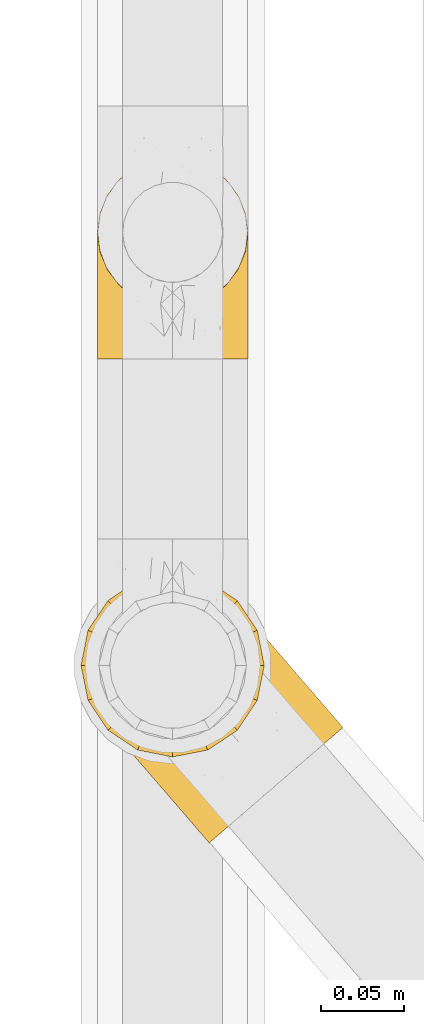
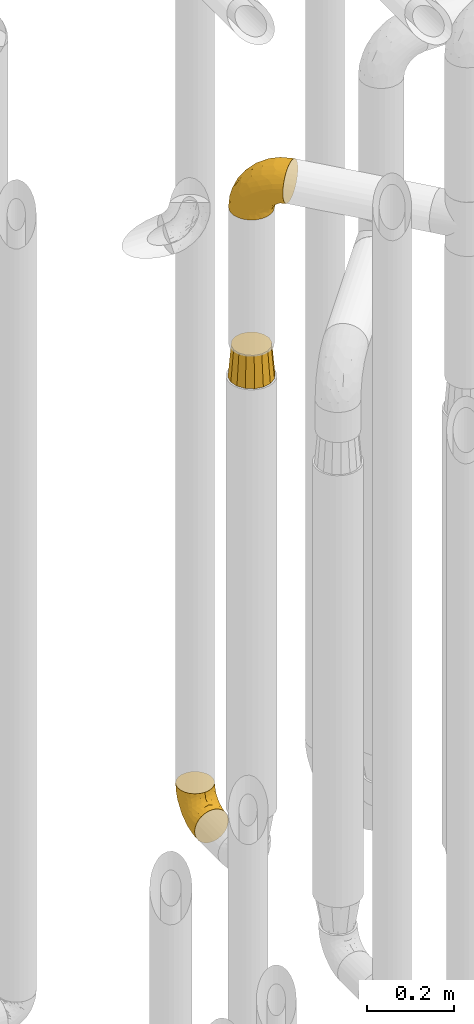
# One storey, part 226 of 827: 3 coverings.
"""IFC2X3 building model written with IfcOpenShell, lengths in millimetres."""

from ifc_helpers import new_model, entity, si_unit, converted_unit, derived_unit, direction, frame, origin, place, context, subcontext, project, spatial, faceted_brep, element, save


model = new_model("IFC2X3")

# Units and contexts
model_context = context("Model", 3, precision=0.01, world=origin(), true_north=direction((6.12303176911189e-17, 1.0)))
body_context = subcontext(model_context, "Body", "Model", "MODEL_VIEW")
ifc_project = project(units=[si_unit("LENGTHUNIT", "METRE", prefix="MILLI"), si_unit("AREAUNIT", "SQUARE_METRE"), si_unit("VOLUMEUNIT", "CUBIC_METRE"), converted_unit("PLANEANGLEUNIT", "DEGREE", entity("IfcRatioMeasure", 0.0174532925199433), si_unit("PLANEANGLEUNIT", "RADIAN"), dimensions=[0, 0, 0, 0, 0, 0, 0]), si_unit("MASSUNIT", "GRAM", prefix="KILO"), derived_unit("MASSDENSITYUNIT", [(si_unit("MASSUNIT", "GRAM", prefix="KILO"), 1), (si_unit("LENGTHUNIT", "METRE"), -3)]), derived_unit("MOMENTOFINERTIAUNIT", [(si_unit("LENGTHUNIT", "METRE"), 4)]), si_unit("TIMEUNIT", "SECOND"), si_unit("FREQUENCYUNIT", "HERTZ"), si_unit("THERMODYNAMICTEMPERATUREUNIT", "DEGREE_CELSIUS"), derived_unit("THERMALTRANSMITTANCEUNIT", [(si_unit("MASSUNIT", "GRAM", prefix="KILO"), 1), (si_unit("THERMODYNAMICTEMPERATUREUNIT", "KELVIN"), -1), (si_unit("TIMEUNIT", "SECOND"), -3)]), derived_unit("VOLUMETRICFLOWRATEUNIT", [(si_unit("LENGTHUNIT", "METRE"), 3), (si_unit("TIMEUNIT", "SECOND"), -1)]), derived_unit("MASSFLOWRATEUNIT", [(si_unit("MASSUNIT", "GRAM", prefix="KILO"), 1), (si_unit("TIMEUNIT", "SECOND"), -1)]), derived_unit("ROTATIONALFREQUENCYUNIT", [(si_unit("TIMEUNIT", "SECOND"), -1)]), si_unit("ELECTRICCURRENTUNIT", "AMPERE"), si_unit("ELECTRICVOLTAGEUNIT", "VOLT"), si_unit("POWERUNIT", "WATT"), si_unit("FORCEUNIT", "NEWTON", prefix="KILO"), si_unit("ILLUMINANCEUNIT", "LUX"), si_unit("LUMINOUSFLUXUNIT", "LUMEN"), si_unit("LUMINOUSINTENSITYUNIT", "CANDELA"), derived_unit("USERDEFINED", [(si_unit("MASSUNIT", "GRAM", prefix="KILO"), -1), (si_unit("LENGTHUNIT", "METRE"), -2), (si_unit("TIMEUNIT", "SECOND"), 3), (si_unit("LUMINOUSFLUXUNIT", "LUMEN"), 1)]), derived_unit("LINEARVELOCITYUNIT", [(si_unit("LENGTHUNIT", "METRE"), 1), (si_unit("TIMEUNIT", "SECOND"), -1)]), si_unit("PRESSUREUNIT", "PASCAL"), derived_unit("USERDEFINED", [(si_unit("LENGTHUNIT", "METRE"), -2), (si_unit("MASSUNIT", "GRAM", prefix="KILO"), 1), (si_unit("TIMEUNIT", "SECOND"), -2)]), derived_unit("LINEARFORCEUNIT", [(si_unit("MASSUNIT", "GRAM", prefix="KILO"), 1), (si_unit("LENGTHUNIT", "METRE"), 1), (si_unit("TIMEUNIT", "SECOND"), -2), (si_unit("LENGTHUNIT", "METRE"), -1)]), derived_unit("PLANARFORCEUNIT", [(si_unit("MASSUNIT", "GRAM", prefix="KILO"), 1), (si_unit("LENGTHUNIT", "METRE"), 1), (si_unit("TIMEUNIT", "SECOND"), -2), (si_unit("LENGTHUNIT", "METRE"), -2)])], contexts=[model_context])

# Site, building, storey
site_placement = place(None, origin())
site = spatial("IfcSite", under=ifc_project, at=site_placement, CompositionType="ELEMENT")
building_placement = place(site_placement, origin())
building = spatial("IfcBuilding", under=site, at=building_placement, CompositionType="ELEMENT")
storey_placement = place(building_placement, frame((0.0, 0.0, 28200.0)))
storey = spatial("IfcBuildingStorey", under=building, at=storey_placement, Name="08", CompositionType="ELEMENT", Elevation=28200.0)

# Coverings
covering_1_placement = place(storey_placement, frame((36582.9, 13162.61, 353.25)))
element("IfcCovering", 1, at=covering_1_placement, inside=storey, Name=":ADSK_", ObjectType=":ADSK_", PredefinedType="INSULATION", context=body_context, shape_type="Brep", body=[
    faceted_brep([(2.73, 1.6, 36.69), (6.07, 1.6, 27.15), (11.45, 1.6, 18.59), (18.6, 1.6, 11.44), (27.16, 1.6, 6.06), (36.7, 1.6, 2.73), (46.75, 1.6, 1.6), (56.8, 1.6, 2.73), (66.34, 1.6, 6.07), (74.9, 1.6, 11.45), (82.05, 1.6, 18.6), (87.43, 1.6, 27.16), (90.76, 1.6, 36.7), (91.9, 1.6, 46.75), (90.76, 1.6, 56.8), (87.42, 1.6, 66.34), (82.04, 1.6, 74.9), (74.89, 1.6, 82.05), (66.33, 1.6, 87.43), (56.79, 1.6, 90.76), (46.75, 1.6, 91.9), (36.69, 1.6, 90.76), (27.15, 1.6, 87.42), (18.59, 1.6, 82.04), (11.44, 1.6, 74.89), (6.06, 1.6, 66.33), (2.73, 1.6, 56.79), (1.6, 1.6, 46.75), (58.43, 33.98, 122.75), (69.32, 38.49, 122.75), (78.67, 45.67, 122.75), (85.85, 55.02, 122.75), (90.36, 65.91, 122.75), (91.9, 77.6, 122.75), (90.36, 89.28, 122.75), (85.85, 100.17, 122.75), (78.67, 109.52, 122.75), (69.32, 116.7, 122.75), (58.43, 121.21, 122.75), (46.75, 122.75, 122.75), (35.06, 121.21, 122.75), (24.17, 116.7, 122.75), (14.82, 109.52, 122.75), (7.64, 100.17, 122.75), (3.13, 89.28, 122.75), (1.6, 77.6, 122.75), (3.13, 65.91, 122.75), (7.64, 55.02, 122.75), (14.82, 45.67, 122.75), (24.17, 38.49, 122.75), (35.06, 33.98, 122.75), (46.75, 32.45, 122.75), (46.75, 72.81, 24.73), (38.29, 77.17, 29.08), (46.75, 86.21, 38.13), (46.75, 116.82, 85.31), (38.96, 118.49, 93.59), (46.75, 119.23, 100.54), (33.86, 105.14, 63.54), (31.42, 85.37, 38.98), (21.63, 89.33, 50.71), (30.84, 116.14, 93.33), (22.16, 105.06, 75.2), (20.56, 112.15, 100.46), (2.29, 22.95, 41.6), (7.18, 89.91, 80.86), (12.6, 103.39, 94.87), (14.0, 93.6, 67.96), (2.81, 51.41, 52.16), (6.65, 67.71, 52.1), (6.11, 43.53, 36.74), (16.62, 30.91, 17.11), (9.76, 23.58, 23.24), (12.46, 50.07, 29.18), (1.6, 30.68, 52.53), (1.6, 43.01, 60.77), (1.6, 55.34, 69.01), (2.46, 83.48, 100.68), (5.91, 94.96, 103.79), (36.97, 57.29, 16.37), (46.75, 39.03, 7.52), (33.09, 30.66, 7.31), (1.6, 71.81, 93.66), (1.6, 73.63, 102.83), (1.6, 75.46, 112.01), (25.62, 51.57, 18.17), (3.14, 73.13, 71.97), (23.92, 23.16, 9.83), (46.75, 23.8, 5.11), (13.58, 75.6, 45.97), (1.6, 12.33, 48.88), (1.6, 21.51, 50.71), (18.5, 50.46, 22.83), (46.75, 99.61, 51.54), (1.6, 63.57, 81.33), (4.96, 21.26, 31.74), (20.84, 69.54, 32.48), (46.75, 108.21, 68.42), (30.52, 68.42, 25.33), (46.75, 55.92, 16.13), (27.29, 19.36, 92.29), (36.89, 15.76, 94.12), (33.6, 26.13, 100.97), (2.54, 62.78, 95.91), (3.27, 63.65, 107.9), (16.85, 24.34, 87.24), (21.91, 28.46, 95.46), (13.5, 33.53, 90.41), (3.96, 39.46, 74.17), (3.52, 51.05, 83.77), (12.17, 10.94, 76.72), (18.93, 14.55, 84.44), (9.34, 22.21, 76.42), (3.12, 57.05, 90.07), (5.67, 54.0, 99.69), (2.51, 29.19, 61.74), (2.53, 18.85, 58.16), (8.35, 52.84, 112.6), (35.39, 31.47, 110.45), (46.75, 28.31, 107.32), (15.1, 43.0, 108.48), (5.27, 16.9, 66.63), (27.43, 35.98, 115.23), (24.89, 33.91, 105.79), (29.71, 9.97, 89.6), (5.07, 25.93, 69.39), (2.88, 35.61, 66.99), (9.69, 47.45, 102.31), (15.51, 38.26, 99.54), (2.27, 11.7, 55.27), (10.03, 30.13, 82.03), (46.75, 12.12, 94.71), (46.75, 17.02, 96.03), (8.83, 44.39, 94.11), (7.16, 39.83, 84.21), (46.75, 22.67, 101.67), (46.75, 29.63, 112.22), (78.39, 43.0, 108.48), (83.8, 47.45, 102.31), (77.97, 38.26, 99.54), (84.66, 44.38, 94.11), (58.1, 31.47, 110.46), (81.31, 10.93, 76.74), (91.9, 21.51, 50.71), (90.96, 18.84, 58.17), (91.22, 11.7, 55.27), (56.59, 15.76, 94.12), (66.18, 19.36, 92.3), (59.87, 26.14, 100.98), (88.42, 25.94, 69.41), (84.13, 22.21, 76.44), (88.22, 16.9, 66.65), (66.06, 35.98, 115.24), (91.9, 73.63, 102.83), (91.9, 75.46, 112.01), (83.44, 30.12, 82.05), (76.62, 24.33, 87.25), (85.14, 52.84, 112.6), (90.22, 63.65, 107.9), (91.9, 71.81, 93.66), (71.55, 28.45, 95.48), (63.77, 9.97, 89.6), (91.9, 43.01, 60.77), (91.9, 55.34, 69.01), (89.53, 39.46, 74.17), (91.9, 12.33, 48.88), (74.55, 14.54, 84.45), (90.95, 62.78, 95.91), (90.37, 57.05, 90.07), (91.9, 63.57, 81.33), (90.98, 29.2, 61.75), (89.97, 51.05, 83.77), (86.32, 39.81, 84.21), (91.9, 30.68, 52.53), (79.97, 33.52, 90.42), (90.61, 35.61, 67.0), (87.82, 54.0, 99.69), (68.6, 33.91, 105.8), (80.89, 103.39, 94.87), (86.31, 89.91, 80.86), (79.49, 93.6, 67.95), (71.33, 105.05, 75.17), (71.88, 89.27, 50.65), (90.35, 73.13, 71.97), (86.85, 67.67, 52.08), (72.67, 69.49, 32.46), (62.08, 85.36, 38.98), (87.58, 94.96, 103.79), (91.03, 83.48, 100.68), (59.62, 105.14, 63.54), (62.65, 116.13, 93.32), (54.53, 118.49, 93.59), (72.93, 112.15, 100.44), (90.68, 51.41, 52.17), (87.39, 43.51, 36.75), (91.2, 22.95, 41.61), (60.41, 30.66, 7.31), (76.88, 30.91, 17.12), (56.53, 57.3, 16.37), (83.74, 23.58, 23.26), (67.88, 51.56, 18.17), (62.99, 68.41, 25.33), (69.58, 23.16, 9.84), (81.04, 50.07, 29.19), (75.0, 50.45, 22.84), (88.53, 21.25, 31.75), (79.93, 75.56, 45.96), (55.21, 77.16, 29.07)], [[[0, 1, 2, 3, 4, 5, 6, 7, 8, 9, 10, 11, 12, 13, 14, 15, 16, 17, 18, 19, 20, 21, 22, 23, 24, 25, 26, 27]], [[28, 29, 30, 31, 32, 33, 34, 35, 36, 37, 38, 39, 40, 41, 42, 43, 44, 45, 46, 47, 48, 49, 50, 51]], [[52, 53, 54]], [[55, 56, 57]], [[58, 59, 60]], [[61, 62, 63]], [[27, 64, 0]], [[65, 66, 67]], [[41, 40, 61]], [[68, 69, 70]], [[66, 43, 42]], [[63, 42, 41]], [[71, 72, 73]], [[72, 2, 1]], [[68, 74, 75, 76]], [[45, 44, 77]], [[43, 78, 44]], [[79, 80, 81]], [[77, 82, 83, 84, 45]], [[79, 81, 85]], [[71, 2, 72]], [[65, 86, 77]], [[4, 81, 5]], [[66, 65, 78]], [[4, 3, 87]], [[81, 88, 5]], [[63, 66, 42]], [[68, 70, 64]], [[67, 60, 89]], [[71, 3, 2]], [[64, 27, 90, 91, 74]], [[92, 71, 73]], [[40, 57, 56]], [[59, 93, 54]], [[86, 76, 94, 82]], [[1, 0, 95]], [[58, 62, 61]], [[60, 96, 89]], [[85, 81, 87]], [[56, 97, 58]], [[65, 67, 69]], [[87, 81, 4]], [[67, 89, 69]], [[61, 63, 41]], [[95, 72, 1]], [[73, 72, 70]], [[69, 73, 70]], [[73, 89, 96]], [[3, 71, 87]], [[85, 87, 71]], [[58, 61, 56]], [[59, 58, 93]], [[76, 86, 68]], [[69, 89, 73]], [[68, 86, 69]], [[65, 69, 86]], [[68, 64, 74]], [[95, 64, 70]], [[98, 79, 85]], [[79, 52, 99, 80]], [[66, 62, 67]], [[62, 58, 60]], [[62, 60, 67]], [[59, 98, 96]], [[59, 96, 60]], [[96, 85, 92]], [[88, 81, 80]], [[88, 6, 5]], [[66, 63, 62]], [[64, 95, 0]], [[72, 95, 70]], [[77, 44, 78]], [[86, 82, 77]], [[40, 39, 57]], [[96, 98, 85]], [[40, 56, 61]], [[66, 78, 43]], [[77, 78, 65]], [[79, 98, 53]], [[96, 92, 73]], [[85, 71, 92]], [[97, 56, 55]], [[97, 93, 58]], [[53, 98, 59]], [[54, 53, 59]], [[79, 53, 52]], [[100, 101, 102]], [[46, 45, 84, 83]], [[103, 104, 82]], [[82, 104, 83]], [[105, 106, 107]], [[108, 109, 76]], [[110, 111, 112]], [[103, 113, 114]], [[115, 74, 116]], [[48, 47, 117]], [[118, 102, 119]], [[49, 48, 120]], [[74, 91, 116]], [[116, 121, 115]], [[49, 122, 50]], [[123, 106, 102]], [[124, 111, 22]], [[125, 126, 115]], [[23, 22, 111]], [[24, 110, 121]], [[120, 127, 128]], [[90, 26, 129]], [[27, 26, 90]], [[121, 125, 115]], [[24, 121, 25]], [[130, 105, 107]], [[129, 25, 116]], [[21, 20, 131]], [[120, 123, 122]], [[112, 105, 130]], [[50, 118, 51]], [[21, 124, 22]], [[101, 131, 132]], [[117, 120, 48]], [[24, 23, 110]], [[127, 114, 133]], [[75, 108, 76]], [[107, 134, 130]], [[133, 114, 113]], [[129, 116, 91]], [[25, 121, 116]], [[121, 112, 125]], [[75, 74, 115]], [[101, 135, 102]], [[131, 101, 21]], [[101, 100, 124]], [[128, 127, 133]], [[119, 136, 51, 118]], [[104, 47, 46]], [[83, 104, 46]], [[117, 104, 114]], [[101, 124, 21]], [[111, 124, 100]], [[102, 118, 123]], [[133, 134, 107]], [[111, 110, 23]], [[114, 104, 103]], [[94, 76, 109]], [[121, 110, 112]], [[122, 118, 50]], [[134, 109, 108]], [[133, 107, 128]], [[112, 108, 125]], [[126, 125, 108]], [[108, 75, 126]], [[75, 115, 126]], [[109, 134, 133]], [[130, 108, 112]], [[108, 130, 134]], [[105, 112, 111]], [[111, 100, 105]], [[106, 105, 100]], [[102, 106, 100]], [[128, 106, 123]], [[90, 129, 91]], [[25, 129, 26]], [[104, 117, 47]], [[117, 114, 127]], [[82, 94, 103]], [[113, 94, 109]], [[94, 113, 103]], [[133, 113, 109]], [[106, 128, 107]], [[123, 120, 128]], [[120, 122, 49]], [[118, 122, 123]], [[135, 101, 132]], [[135, 119, 102]], [[117, 127, 120]], [[30, 29, 137]], [[138, 139, 140]], [[51, 136, 119, 141]], [[142, 17, 16]], [[143, 144, 145]], [[146, 147, 148]], [[149, 150, 151]], [[152, 29, 28]], [[33, 32, 153, 154]], [[150, 155, 156]], [[157, 31, 30]], [[153, 158, 159]], [[29, 152, 137]], [[148, 141, 119]], [[156, 160, 147]], [[148, 135, 146]], [[137, 138, 157]], [[19, 161, 146]], [[162, 163, 164]], [[14, 13, 165]], [[153, 32, 158]], [[147, 161, 166]], [[18, 17, 166]], [[167, 168, 169]], [[166, 150, 156]], [[151, 150, 142]], [[151, 170, 149]], [[151, 16, 15]], [[171, 140, 172]], [[165, 143, 145]], [[173, 170, 144]], [[142, 166, 17]], [[19, 131, 20]], [[144, 170, 151]], [[18, 161, 19]], [[173, 144, 143]], [[140, 139, 174]], [[171, 164, 163]], [[164, 172, 155]], [[151, 15, 144]], [[145, 15, 14]], [[173, 162, 170]], [[149, 175, 164]], [[19, 146, 131]], [[132, 131, 146]], [[160, 148, 147]], [[159, 158, 167]], [[135, 132, 146]], [[158, 32, 31]], [[157, 158, 31]], [[167, 158, 176]], [[166, 161, 18]], [[146, 161, 147]], [[148, 177, 141]], [[171, 168, 140]], [[171, 163, 169]], [[151, 142, 16]], [[166, 142, 150]], [[152, 141, 177]], [[51, 141, 28]], [[138, 140, 176]], [[172, 140, 174]], [[175, 149, 170]], [[164, 150, 149]], [[170, 162, 175]], [[162, 164, 175]], [[155, 172, 174]], [[171, 172, 164]], [[155, 174, 156]], [[164, 155, 150]], [[160, 156, 174]], [[147, 166, 156]], [[139, 160, 174]], [[148, 160, 177]], [[15, 145, 144]], [[165, 145, 14]], [[137, 157, 30]], [[158, 157, 176]], [[168, 167, 176]], [[169, 159, 167]], [[140, 168, 176]], [[169, 168, 171]], [[137, 177, 139]], [[160, 139, 177]], [[141, 152, 28]], [[137, 152, 177]], [[148, 119, 135]], [[157, 138, 176]], [[139, 138, 137]], [[178, 179, 180]], [[181, 180, 182]], [[179, 183, 184]], [[185, 186, 182]], [[187, 188, 179]], [[188, 33, 154, 153, 159]], [[181, 189, 190]], [[35, 34, 187]], [[191, 38, 190]], [[192, 178, 181]], [[179, 184, 180]], [[192, 190, 37]], [[37, 190, 38]], [[36, 35, 178]], [[54, 93, 186]], [[35, 187, 178]], [[193, 194, 184]], [[195, 173, 143, 165, 13]], [[195, 193, 173]], [[193, 163, 162, 173]], [[13, 12, 195]], [[8, 7, 196]], [[9, 197, 10]], [[198, 80, 99, 52]], [[196, 7, 88]], [[197, 199, 10]], [[182, 189, 181]], [[200, 198, 201]], [[200, 196, 198]], [[9, 8, 202]], [[194, 199, 203]], [[192, 37, 36]], [[80, 196, 88]], [[183, 159, 169, 163]], [[188, 34, 33]], [[202, 200, 197]], [[185, 203, 204]], [[202, 8, 196]], [[10, 199, 11]], [[12, 11, 205]], [[38, 191, 57]], [[189, 97, 191]], [[203, 199, 197]], [[205, 199, 194]], [[204, 203, 197]], [[184, 203, 206]], [[200, 202, 196]], [[197, 9, 202]], [[207, 54, 186]], [[97, 55, 191]], [[194, 203, 184]], [[183, 163, 193]], [[184, 206, 180]], [[183, 193, 184]], [[205, 195, 12]], [[193, 195, 194]], [[80, 198, 196]], [[207, 186, 201]], [[182, 180, 206]], [[181, 178, 180]], [[185, 182, 206]], [[182, 186, 189]], [[203, 185, 206]], [[185, 200, 201]], [[7, 6, 88]], [[178, 192, 36]], [[190, 192, 181]], [[199, 205, 11]], [[195, 205, 194]], [[159, 183, 188]], [[179, 188, 183]], [[57, 191, 55]], [[57, 39, 38]], [[189, 191, 190]], [[188, 187, 34]], [[178, 187, 179]], [[186, 93, 189]], [[197, 200, 204]], [[185, 204, 200]], [[189, 93, 97]], [[207, 198, 52]], [[185, 201, 186]], [[198, 207, 201]], [[54, 207, 52]]]),
])
covering_2_placement = place(storey_placement, frame((36575.14, 12872.03, 2253.4)))
element("IfcCovering", 2, at=covering_2_placement, inside=storey, Name=":ADSK_", ObjectType=":ADSK_", PredefinedType="INSULATION", context=body_context, shape_type="Brep", body=[
    faceted_brep([(125.52, 43.98, 148.32), (116.59, 36.27, 149.65), (107.66, 28.55, 148.31), (99.17, 21.22, 144.39), (91.55, 14.64, 138.06), (85.2, 9.15, 129.66), (80.42, 5.03, 119.6), (77.45, 2.46, 108.39), (76.44, 1.6, 96.6), (77.45, 2.47, 84.79), (80.42, 5.03, 73.57), (85.21, 9.16, 63.51), (91.57, 14.66, 55.11), (99.18, 21.23, 48.79), (107.67, 28.56, 44.87), (116.59, 36.27, 43.55), (125.53, 43.99, 44.88), (134.02, 51.32, 48.8), (141.63, 57.89, 55.13), (147.99, 63.38, 63.53), (152.77, 67.51, 73.59), (155.74, 70.07, 84.8), (156.75, 70.94, 96.6), (155.74, 70.07, 108.41), (152.77, 67.51, 119.62), (147.98, 63.37, 129.68), (141.62, 57.88, 138.08), (134.01, 51.31, 144.4), (77.6, 60.41, 1.6), (64.46, 56.06, 1.6), (50.63, 55.26, 1.6), (37.07, 58.07, 1.6), (24.7, 64.29, 1.6), (14.35, 73.5, 1.6), (6.75, 85.07, 1.6), (2.4, 98.22, 1.6), (1.6, 112.04, 1.6), (4.4, 125.6, 1.6), (10.62, 137.98, 1.6), (19.83, 148.32, 1.6), (31.4, 155.93, 1.6), (44.55, 160.28, 1.6), (58.38, 161.08, 1.6), (71.94, 158.27, 1.6), (84.31, 152.05, 1.6), (94.65, 142.84, 1.6), (102.26, 131.27, 1.6), (106.61, 118.12, 1.6), (107.41, 104.3, 1.6), (104.61, 90.73, 1.6), (98.39, 78.36, 1.6), (89.18, 68.02, 1.6), (51.35, 159.08, 27.97), (39.18, 154.64, 37.09), (55.45, 151.65, 58.27), (29.11, 152.23, 27.13), (23.13, 144.5, 39.91), (103.88, 115.37, 109.11), (85.23, 131.82, 94.41), (83.2, 120.56, 110.94), (53.69, 134.69, 89.69), (32.79, 133.31, 75.62), (48.17, 115.5, 106.28), (88.29, 143.75, 60.12), (76.96, 152.95, 41.41), (79.95, 146.72, 63.22), (85.72, 149.73, 32.05), (96.08, 139.8, 52.13), (105.4, 103.03, 123.27), (95.19, 99.22, 129.32), (114.54, 79.42, 138.3), (45.82, 147.85, 62.95), (34.36, 146.02, 55.89), (65.46, 156.85, 37.4), (91.55, 65.27, 144.6), (105.35, 73.91, 142.66), (68.92, 112.37, 117.85), (83.78, 91.71, 134.01), (96.7, 129.82, 89.25), (139.67, 89.32, 103.34), (135.16, 89.67, 113.52), (106.51, 129.11, 57.43), (102.1, 134.22, 44.19), (97.69, 139.32, 30.95), (105.59, 127.69, 77.98), (125.53, 80.92, 132.66), (122.95, 94.37, 121.52), (67.61, 138.68, 86.93), (71.95, 147.11, 68.4), (120.25, 113.2, 78.45), (113.38, 121.16, 67.94), (148.22, 80.81, 94.53), (137.56, 93.16, 91.95), (123.03, 108.59, 93.36), (128.9, 103.18, 85.2), (115.3, 112.48, 101.45), (68.21, 92.29, 129.81), (96.17, 141.08, 16.27), (118.48, 68.28, 42.46), (117.39, 80.68, 40.4), (124.87, 82.47, 49.71), (107.56, 125.69, 39.4), (109.79, 117.53, 31.26), (104.7, 128.74, 27.7), (101.82, 132.81, 16.7), (129.35, 99.09, 70.67), (137.5, 91.76, 81.69), (107.25, 118.91, 16.68), (92.85, 63.76, 22.57), (91.39, 65.45, 14.26), (100.01, 75.47, 17.68), (109.23, 100.97, 19.58), (113.57, 100.48, 33.49), (113.23, 89.81, 33.01), (113.14, 57.4, 40.69), (108.32, 45.85, 40.15), (102.89, 52.14, 37.93), (106.11, 70.25, 31.04), (116.74, 106.75, 45.29), (107.53, 85.3, 23.55), (103.59, 85.72, 11.36), (117.8, 113.29, 59.1), (124.29, 99.09, 57.42), (122.27, 109.37, 68.96), (109.18, 110.81, 20.38), (140.85, 82.29, 72.46), (146.48, 80.83, 83.66), (132.44, 84.4, 60.66), (139.38, 71.66, 61.01), (130.26, 69.79, 51.85), (124.47, 57.4, 46.07), (97.87, 57.95, 30.25), (112.36, 118.65, 46.65), (118.78, 92.23, 43.0), (53.66, 52.98, 19.58), (67.54, 18.98, 72.44), (80.23, 58.39, 17.67), (39.95, 43.86, 78.45), (43.44, 41.3, 68.97), (52.58, 32.81, 70.65), (96.2, 42.77, 40.69), (84.68, 39.07, 42.45), (84.52, 51.59, 31.04), (60.94, 42.26, 42.99), (46.79, 46.46, 45.18), (53.57, 48.61, 33.46), (66.68, 27.61, 60.64), (53.33, 37.82, 57.37), (26.21, 59.76, 57.43), (21.8, 64.87, 44.19), (29.45, 58.23, 39.35), (15.87, 71.74, 16.27), (23.23, 64.95, 16.7), (57.26, 23.81, 91.95), (48.6, 33.84, 85.2), (58.62, 23.7, 81.68), (35.65, 52.49, 46.68), (37.2, 54.84, 31.26), (36.2, 57.54, 16.68), (26.84, 61.5, 27.7), (78.28, 18.89, 60.99), (81.46, 27.64, 51.84), (72.56, 41.94, 40.41), (69.68, 34.8, 49.72), (94.56, 31.56, 46.06), (67.92, 11.47, 94.53), (69.57, 56.33, 11.35), (64.16, 47.39, 33.02), (68.16, 13.2, 83.65), (43.93, 54.46, 20.38), (33.08, 51.81, 67.94), (69.4, 52.38, 23.53), (40.2, 46.3, 59.12), (17.39, 69.98, 30.95), (11.35, 113.57, 58.27), (4.6, 118.71, 27.97), (4.75, 104.42, 37.4), (6.93, 92.48, 41.41), (14.62, 139.7, 27.21), (10.76, 130.1, 37.09), (19.3, 134.39, 53.2), (17.15, 71.64, 52.13), (60.74, 21.17, 103.34), (61.06, 25.67, 113.5), (41.39, 48.65, 101.45), (26.63, 81.21, 94.41), (40.18, 60.34, 109.08), (38.07, 81.55, 110.95), (44.1, 40.43, 93.36), (27.75, 60.47, 77.98), (8.84, 83.34, 32.05), (17.31, 122.48, 64.63), (52.16, 57.06, 123.25), (71.11, 33.91, 132.65), (57.44, 66.58, 129.32), (79.2, 38.73, 139.96), (48.25, 94.52, 117.85), (28.38, 112.84, 89.69), (58.2, 38.41, 121.51), (12.66, 88.61, 63.23), (26.89, 69.61, 89.17), (80.98, 52.86, 142.66), (13.44, 96.59, 68.4), (22.41, 99.65, 86.94), (14.38, 79.93, 60.12), (64.39, 75.17, 133.2)], [[[0, 1, 2, 3, 4, 5, 6, 7, 8, 9, 10, 11, 12, 13, 14, 15, 16, 17, 18, 19, 20, 21, 22, 23, 24, 25, 26, 27]], [[28, 29, 30, 31, 32, 33, 34, 35, 36, 37, 38, 39, 40, 41, 42, 43, 44, 45, 46, 47, 48, 49, 50, 51]], [[52, 53, 54]], [[55, 39, 56]], [[57, 58, 59]], [[60, 61, 62]], [[63, 64, 65]], [[66, 63, 67]], [[68, 69, 70]], [[53, 71, 54]], [[41, 40, 53]], [[53, 72, 71]], [[73, 42, 52]], [[42, 41, 52]], [[74, 0, 75]], [[69, 76, 77]], [[43, 73, 64]], [[45, 44, 66]], [[57, 78, 58]], [[23, 79, 80]], [[67, 81, 82, 83]], [[67, 84, 81]], [[24, 23, 80]], [[25, 85, 26]], [[86, 85, 25]], [[42, 73, 43]], [[0, 27, 75]], [[25, 24, 86]], [[70, 26, 85]], [[0, 74, 1]], [[68, 85, 86]], [[66, 64, 63]], [[60, 59, 87]], [[54, 87, 88]], [[76, 60, 62]], [[84, 89, 90, 81]], [[79, 22, 91, 92]], [[77, 74, 75]], [[93, 92, 94, 89]], [[80, 86, 24]], [[40, 55, 53]], [[76, 59, 60]], [[93, 84, 95]], [[76, 62, 96]], [[55, 72, 53]], [[70, 27, 26]], [[75, 70, 69]], [[78, 84, 63]], [[93, 79, 92]], [[95, 86, 80]], [[77, 76, 96]], [[59, 69, 68]], [[57, 68, 86]], [[68, 57, 59]], [[59, 58, 87]], [[76, 69, 59]], [[88, 87, 58]], [[87, 54, 71]], [[86, 95, 57]], [[78, 57, 95]], [[84, 78, 95]], [[78, 63, 65]], [[58, 78, 65]], [[54, 88, 73]], [[84, 93, 89]], [[79, 95, 80]], [[79, 93, 95]], [[22, 79, 23]], [[66, 83, 97, 45]], [[84, 67, 63]], [[83, 66, 67]], [[64, 44, 43]], [[64, 66, 44]], [[65, 73, 88]], [[53, 52, 41]], [[73, 52, 54]], [[73, 65, 64]], [[65, 88, 58]], [[39, 55, 40]], [[72, 55, 56]], [[56, 61, 72]], [[60, 72, 61]], [[72, 60, 71]], [[87, 71, 60]], [[27, 70, 75]], [[68, 70, 85]], [[74, 77, 96]], [[69, 77, 75]], [[98, 99, 100]], [[46, 45, 97]], [[101, 102, 103]], [[103, 104, 83]], [[105, 94, 106]], [[107, 103, 102]], [[108, 109, 51, 110]], [[111, 112, 113]], [[114, 115, 116]], [[47, 104, 107]], [[110, 117, 108]], [[49, 48, 111]], [[102, 118, 112]], [[119, 120, 111]], [[50, 49, 120]], [[121, 122, 118]], [[105, 123, 89]], [[124, 48, 107]], [[20, 19, 125]], [[121, 81, 90]], [[117, 119, 99]], [[21, 20, 126]], [[22, 21, 91]], [[105, 125, 127]], [[110, 51, 50]], [[19, 128, 125]], [[16, 15, 115]], [[129, 98, 100]], [[126, 91, 21]], [[128, 129, 127]], [[122, 123, 105]], [[114, 117, 98]], [[17, 16, 130]], [[18, 128, 19]], [[129, 18, 17]], [[125, 106, 126]], [[115, 114, 16]], [[130, 129, 17]], [[114, 98, 130]], [[117, 116, 131, 108]], [[99, 119, 113]], [[122, 121, 123]], [[92, 126, 106]], [[105, 127, 122]], [[132, 121, 118]], [[114, 130, 16]], [[129, 130, 98]], [[50, 120, 110]], [[129, 128, 18]], [[125, 128, 127]], [[125, 126, 20]], [[91, 126, 92]], [[105, 89, 94]], [[105, 106, 125]], [[94, 92, 106]], [[100, 122, 127]], [[118, 122, 133]], [[112, 118, 133]], [[132, 118, 102]], [[132, 102, 101]], [[81, 121, 132]], [[82, 103, 83]], [[132, 101, 81]], [[104, 47, 46]], [[124, 107, 102]], [[48, 47, 107]], [[113, 112, 133]], [[112, 111, 124]], [[99, 113, 133]], [[111, 113, 119]], [[99, 133, 100]], [[117, 99, 98]], [[122, 100, 133]], [[127, 129, 100]], [[103, 82, 101]], [[81, 101, 82]], [[112, 124, 102]], [[48, 124, 111]], [[104, 103, 107]], [[46, 97, 104]], [[111, 120, 49]], [[83, 104, 97]], [[110, 120, 119]], [[117, 110, 119]], [[116, 117, 114]], [[89, 123, 90]], [[90, 123, 121]], [[30, 29, 134]], [[11, 10, 135]], [[51, 109, 108, 136]], [[137, 138, 139]], [[140, 141, 142]], [[143, 144, 145]], [[146, 139, 147]], [[148, 149, 150]], [[151, 32, 152]], [[153, 154, 155]], [[156, 150, 157]], [[158, 157, 159]], [[108, 142, 136]], [[31, 158, 152]], [[160, 161, 12]], [[162, 163, 143]], [[140, 142, 116]], [[142, 141, 162]], [[14, 164, 140]], [[14, 140, 115]], [[9, 8, 165]], [[160, 12, 11]], [[141, 164, 161]], [[13, 12, 161]], [[14, 115, 15]], [[28, 166, 29]], [[135, 139, 146]], [[141, 163, 162]], [[135, 146, 160]], [[143, 167, 162]], [[29, 166, 134]], [[116, 142, 108, 131]], [[165, 153, 168]], [[10, 9, 168]], [[168, 135, 10]], [[138, 147, 139]], [[158, 169, 157]], [[14, 13, 164]], [[116, 115, 140]], [[145, 167, 143]], [[135, 160, 11]], [[168, 153, 155]], [[138, 137, 170]], [[157, 144, 156]], [[147, 144, 143]], [[161, 164, 13]], [[140, 164, 141]], [[142, 171, 136]], [[136, 171, 166]], [[161, 160, 146]], [[165, 168, 9]], [[155, 139, 135]], [[139, 154, 137]], [[168, 155, 135]], [[139, 155, 154]], [[144, 147, 172]], [[163, 147, 143]], [[156, 144, 172]], [[157, 169, 145]], [[172, 148, 156]], [[173, 159, 149]], [[159, 157, 150]], [[152, 159, 173]], [[159, 152, 158]], [[31, 30, 158]], [[169, 30, 134]], [[157, 145, 144]], [[167, 134, 171]], [[134, 167, 145]], [[171, 142, 162]], [[162, 167, 171]], [[163, 141, 161]], [[161, 146, 163]], [[147, 163, 146]], [[148, 150, 156]], [[149, 159, 150]], [[30, 169, 158]], [[145, 169, 134]], [[151, 33, 32]], [[31, 152, 32]], [[152, 173, 151]], [[28, 51, 136]], [[134, 166, 171]], [[28, 136, 166]], [[138, 170, 172]], [[147, 138, 172]], [[148, 172, 170]], [[174, 175, 176]], [[35, 34, 177]], [[178, 179, 180]], [[181, 173, 149, 148]], [[182, 183, 184]], [[185, 186, 187]], [[188, 189, 137]], [[190, 33, 151, 173]], [[191, 179, 174]], [[34, 190, 177]], [[39, 38, 178]], [[192, 193, 194]], [[4, 3, 195]], [[175, 179, 37]], [[38, 37, 179]], [[35, 176, 36]], [[196, 62, 197]], [[181, 190, 173]], [[37, 36, 175]], [[183, 6, 198]], [[189, 148, 170, 137]], [[185, 199, 200]], [[3, 2, 201]], [[202, 185, 203]], [[8, 7, 182]], [[200, 184, 186]], [[183, 7, 6]], [[181, 189, 204]], [[200, 189, 184]], [[5, 198, 6]], [[187, 203, 185]], [[195, 3, 201]], [[205, 196, 194]], [[62, 61, 197]], [[186, 198, 192]], [[180, 179, 191]], [[2, 1, 74]], [[198, 193, 192]], [[193, 5, 4]], [[194, 193, 195]], [[2, 74, 201]], [[5, 193, 198]], [[205, 74, 96]], [[188, 137, 154, 153]], [[62, 196, 96]], [[56, 178, 180]], [[198, 184, 183]], [[184, 188, 182]], [[203, 197, 191]], [[205, 194, 201]], [[187, 192, 194]], [[192, 187, 186]], [[194, 196, 187]], [[197, 187, 196]], [[197, 203, 187]], [[202, 174, 176]], [[200, 186, 185]], [[184, 198, 186]], [[199, 185, 202]], [[189, 200, 204]], [[174, 202, 203]], [[176, 177, 199]], [[189, 181, 148]], [[190, 181, 204]], [[190, 204, 177]], [[190, 34, 33]], [[188, 153, 182]], [[189, 188, 184]], [[182, 153, 165, 8]], [[183, 182, 7]], [[199, 177, 204]], [[35, 177, 176]], [[176, 175, 36]], [[179, 175, 174]], [[200, 199, 204]], [[176, 199, 202]], [[203, 191, 174]], [[180, 197, 61]], [[197, 180, 191]], [[61, 56, 180]], [[39, 178, 56]], [[38, 179, 178]], [[194, 195, 201]], [[4, 195, 193]], [[74, 205, 201]], [[96, 196, 205]]]),
])
covering_3_placement = place(storey_placement, frame((36573.05, 12923.61, 1781.0)))
element("IfcCovering", 3, at=covering_3_placement, inside=storey, Name=":ADSK_", ObjectType=":ADSK_", PredefinedType="INSULATION", context=body_context, shape_type="Brep", body=[
    faceted_brep([(35.55, 107.41, 0.0), (43.51, 108.99, 0.0), (56.6, 111.6, 0.0), (69.69, 108.99, 0.0), (77.64, 107.41, 0.0), (86.56, 101.45, 0.0), (95.49, 95.49, 0.0), (101.45, 86.56, 0.0), (107.41, 77.64, 0.0), (108.99, 69.69, 0.0), (111.6, 56.6, 0.0), (108.99, 43.51, 0.0), (107.41, 35.55, 0.0), (101.45, 26.63, 0.0), (95.49, 17.7, 0.0), (86.56, 11.74, 0.0), (77.64, 5.78, 0.0), (69.69, 4.2, 0.0), (56.6, 1.6, 0.0), (43.51, 4.2, 0.0), (35.55, 5.78, 0.0), (26.63, 11.74, 0.0), (17.7, 17.7, 0.0), (11.74, 26.63, 0.0), (5.78, 35.55, 0.0), (4.2, 43.51, 0.0), (1.6, 56.6, 0.0), (4.2, 69.69, 0.0), (5.78, 77.64, 0.0), (11.74, 86.56, 0.0), (17.7, 95.49, 0.0), (26.63, 101.45, 0.0), (9.1, 56.6, 89.0), (10.9, 47.51, 89.0), (12.71, 38.42, 89.0), (17.86, 30.71, 89.0), (23.01, 23.01, 89.0), (30.71, 17.86, 89.0), (38.42, 12.71, 89.0), (47.51, 10.9, 89.0), (56.6, 9.1, 89.0), (65.68, 10.9, 89.0), (74.77, 12.71, 89.0), (82.48, 17.86, 89.0), (90.18, 23.01, 89.0), (95.33, 30.71, 89.0), (100.48, 38.42, 89.0), (102.29, 47.51, 89.0), (104.1, 56.6, 89.0), (102.29, 65.68, 89.0), (100.48, 74.77, 89.0), (95.33, 82.48, 89.0), (90.18, 90.18, 89.0), (82.48, 95.33, 89.0), (74.77, 100.48, 89.0), (65.68, 102.29, 89.0), (56.6, 104.1, 89.0), (47.51, 102.29, 89.0), (38.42, 100.48, 89.0), (30.71, 95.33, 89.0), (23.01, 90.18, 89.0), (17.86, 82.48, 89.0), (12.71, 74.77, 89.0), (10.9, 65.68, 89.0)], [[[0, 1, 2, 3, 4, 5, 6, 7, 8, 9, 10, 11, 12, 13, 14, 15, 16, 17, 18, 19, 20, 21, 22, 23, 24, 25, 26, 27, 28, 29, 30, 31]], [[32, 33, 34, 35, 36, 37, 38, 39, 40, 41, 42, 43, 44, 45, 46, 47, 48, 49, 50, 51, 52, 53, 54, 55, 56, 57, 58, 59, 60, 61, 62, 63]], [[46, 12, 11, 10, 48, 47]], [[44, 14, 13, 12, 46, 45]], [[42, 16, 15, 14, 44, 43]], [[41, 40, 18, 17, 16, 42]], [[38, 20, 19, 18, 40, 39]], [[36, 22, 21, 20, 38, 37]], [[34, 24, 23, 22, 36, 35]], [[33, 32, 26, 25, 24, 34]], [[62, 28, 27, 26, 32, 63]], [[60, 30, 29, 28, 62, 61]], [[58, 0, 31, 30, 60, 59]], [[57, 56, 2, 1, 0, 58]], [[54, 4, 3, 2, 56, 55]], [[52, 6, 5, 4, 54, 53]], [[50, 8, 7, 6, 52, 51]], [[49, 48, 10, 9, 8, 50]]]),
])

save(model, "model.ifc")
